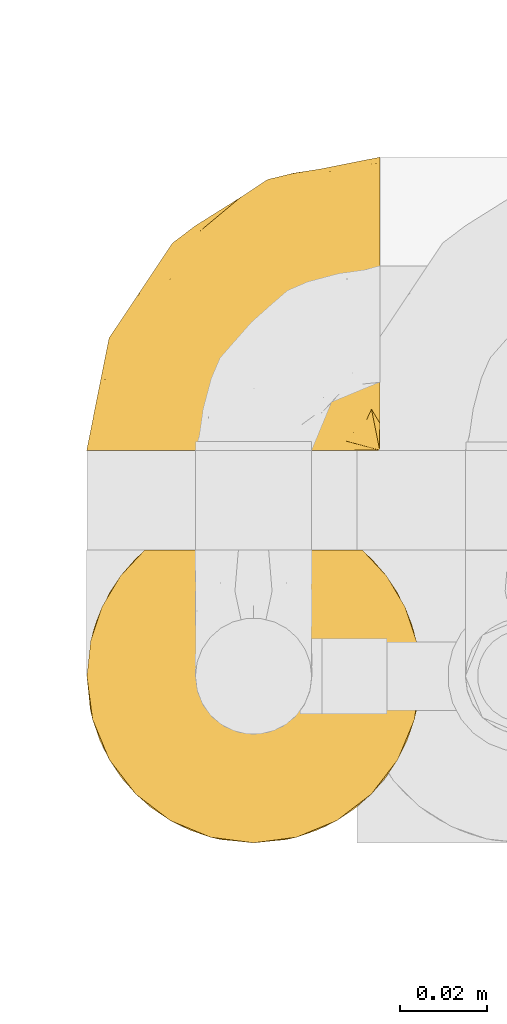
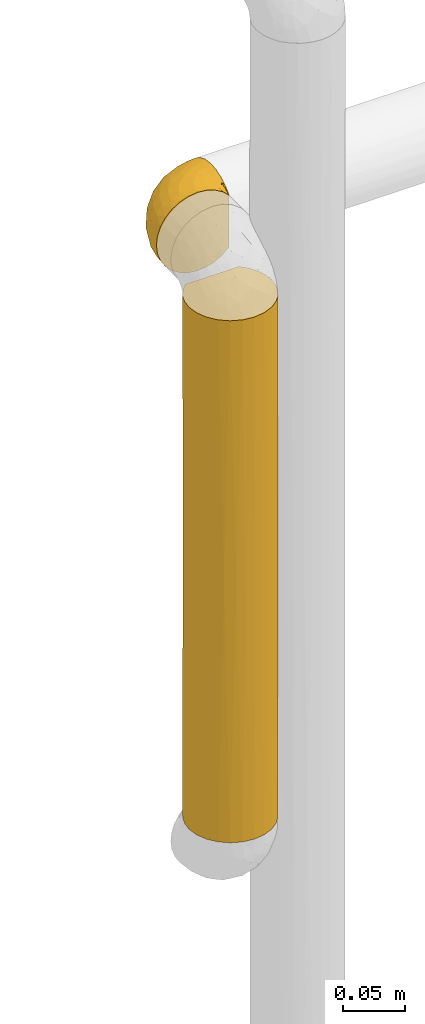
# One storey, part 333 of 827: 2 coverings.
"""IFC2X3 building model written with IfcOpenShell, lengths in millimetres."""

from ifc_helpers import new_model, entity, si_unit, converted_unit, derived_unit, direction, frame, origin, place, context, subcontext, project, spatial, faceted_brep, element, save


model = new_model("IFC2X3")

# Units and contexts
model_context = context("Model", 3, precision=0.01, world=origin(), true_north=direction((6.12303176911189e-17, 1.0)))
body_context = subcontext(model_context, "Body", "Model", "MODEL_VIEW")
ifc_project = project(units=[si_unit("LENGTHUNIT", "METRE", prefix="MILLI"), si_unit("AREAUNIT", "SQUARE_METRE"), si_unit("VOLUMEUNIT", "CUBIC_METRE"), converted_unit("PLANEANGLEUNIT", "DEGREE", entity("IfcRatioMeasure", 0.0174532925199433), si_unit("PLANEANGLEUNIT", "RADIAN"), dimensions=[0, 0, 0, 0, 0, 0, 0]), si_unit("MASSUNIT", "GRAM", prefix="KILO"), derived_unit("MASSDENSITYUNIT", [(si_unit("MASSUNIT", "GRAM", prefix="KILO"), 1), (si_unit("LENGTHUNIT", "METRE"), -3)]), derived_unit("MOMENTOFINERTIAUNIT", [(si_unit("LENGTHUNIT", "METRE"), 4)]), si_unit("TIMEUNIT", "SECOND"), si_unit("FREQUENCYUNIT", "HERTZ"), si_unit("THERMODYNAMICTEMPERATUREUNIT", "DEGREE_CELSIUS"), derived_unit("THERMALTRANSMITTANCEUNIT", [(si_unit("MASSUNIT", "GRAM", prefix="KILO"), 1), (si_unit("THERMODYNAMICTEMPERATUREUNIT", "KELVIN"), -1), (si_unit("TIMEUNIT", "SECOND"), -3)]), derived_unit("VOLUMETRICFLOWRATEUNIT", [(si_unit("LENGTHUNIT", "METRE"), 3), (si_unit("TIMEUNIT", "SECOND"), -1)]), derived_unit("MASSFLOWRATEUNIT", [(si_unit("MASSUNIT", "GRAM", prefix="KILO"), 1), (si_unit("TIMEUNIT", "SECOND"), -1)]), derived_unit("ROTATIONALFREQUENCYUNIT", [(si_unit("TIMEUNIT", "SECOND"), -1)]), si_unit("ELECTRICCURRENTUNIT", "AMPERE"), si_unit("ELECTRICVOLTAGEUNIT", "VOLT"), si_unit("POWERUNIT", "WATT"), si_unit("FORCEUNIT", "NEWTON", prefix="KILO"), si_unit("ILLUMINANCEUNIT", "LUX"), si_unit("LUMINOUSFLUXUNIT", "LUMEN"), si_unit("LUMINOUSINTENSITYUNIT", "CANDELA"), derived_unit("USERDEFINED", [(si_unit("MASSUNIT", "GRAM", prefix="KILO"), -1), (si_unit("LENGTHUNIT", "METRE"), -2), (si_unit("TIMEUNIT", "SECOND"), 3), (si_unit("LUMINOUSFLUXUNIT", "LUMEN"), 1)]), derived_unit("LINEARVELOCITYUNIT", [(si_unit("LENGTHUNIT", "METRE"), 1), (si_unit("TIMEUNIT", "SECOND"), -1)]), si_unit("PRESSUREUNIT", "PASCAL"), derived_unit("USERDEFINED", [(si_unit("LENGTHUNIT", "METRE"), -2), (si_unit("MASSUNIT", "GRAM", prefix="KILO"), 1), (si_unit("TIMEUNIT", "SECOND"), -2)]), derived_unit("LINEARFORCEUNIT", [(si_unit("MASSUNIT", "GRAM", prefix="KILO"), 1), (si_unit("LENGTHUNIT", "METRE"), 1), (si_unit("TIMEUNIT", "SECOND"), -2), (si_unit("LENGTHUNIT", "METRE"), -1)]), derived_unit("PLANARFORCEUNIT", [(si_unit("MASSUNIT", "GRAM", prefix="KILO"), 1), (si_unit("LENGTHUNIT", "METRE"), 1), (si_unit("TIMEUNIT", "SECOND"), -2), (si_unit("LENGTHUNIT", "METRE"), -2)])], contexts=[model_context])

# Site, building, storey
site_placement = place(None, origin())
site = spatial("IfcSite", under=ifc_project, at=site_placement, CompositionType="ELEMENT")
building_placement = place(site_placement, origin())
building = spatial("IfcBuilding", under=site, at=building_placement, CompositionType="ELEMENT")
storey_placement = place(building_placement, frame((0.0, 0.0, 28200.0)))
storey = spatial("IfcBuildingStorey", under=building, at=storey_placement, Name="08", CompositionType="ELEMENT", Elevation=28200.0)

# Coverings
covering_1_placement = place(storey_placement, frame((34953.73, 19463.91, 1659.95)))
element("IfcCovering", 1, at=covering_1_placement, inside=storey, Name=":ADSK_", ObjectType=":ADSK_", PredefinedType="INSULATION", context=body_context, shape_type="Brep", body=[
    faceted_brep([(23.36, 1.6, 74.68), (16.07, 1.6, 70.1), (9.98, 1.6, 64.01), (5.4, 1.6, 56.72), (2.56, 1.6, 48.6), (1.6, 1.6, 40.05), (2.56, 1.6, 31.49), (5.41, 1.6, 23.36), (9.99, 1.6, 16.07), (16.08, 1.6, 9.98), (23.37, 1.6, 5.4), (31.49, 1.6, 2.56), (40.05, 1.6, 1.6), (48.15, 1.6, 2.46), (55.88, 1.6, 5.01), (62.9, 1.6, 9.13), (68.89, 1.6, 14.62), (68.89, 1.6, 16.82), (68.89, 1.6, 18.56), (68.89, 1.6, 20.52), (68.89, 1.6, 22.49), (68.89, 1.6, 24.46), (68.89, 1.6, 26.42), (68.89, 1.6, 28.39), (68.89, 1.6, 30.36), (68.89, 1.6, 32.55), (68.89, 1.6, 34.75), (68.89, 1.6, 36.94), (68.89, 1.6, 39.13), (68.89, 1.6, 41.33), (68.89, 1.6, 43.52), (68.89, 1.6, 45.72), (68.89, 1.6, 47.91), (68.89, 1.6, 50.11), (68.89, 1.6, 52.3), (68.89, 1.6, 54.49), (68.89, 1.6, 56.69), (68.89, 1.6, 58.88), (68.89, 1.6, 61.08), (68.89, 1.6, 63.27), (68.89, 1.6, 65.47), (62.89, 1.6, 70.97), (55.86, 1.6, 75.09), (48.13, 1.6, 77.64), (40.05, 1.6, 78.5), (31.49, 1.6, 77.53), (69.15, 1.85, 14.62), (69.15, 7.85, 9.12), (69.15, 14.87, 5.0), (69.15, 22.6, 2.46), (69.15, 30.7, 1.6), (69.15, 40.65, 2.91), (69.15, 49.92, 6.75), (69.15, 57.88, 12.86), (69.15, 63.99, 20.82), (69.15, 67.84, 30.09), (69.15, 69.15, 40.05), (69.15, 67.84, 50.0), (69.15, 63.99, 59.27), (69.15, 57.88, 67.23), (69.15, 49.92, 73.34), (69.15, 40.65, 77.19), (69.15, 30.7, 78.5), (69.15, 22.6, 77.63), (69.15, 14.87, 75.09), (69.15, 7.85, 70.97), (69.15, 1.85, 65.47), (69.15, 1.85, 63.27), (69.15, 1.85, 62.29), (69.15, 1.85, 60.7), (69.15, 1.85, 59.11), (69.15, 1.85, 57.52), (69.15, 1.85, 55.93), (69.15, 1.85, 54.34), (69.15, 1.85, 52.76), (69.15, 1.85, 51.17), (69.15, 1.85, 49.58), (69.15, 1.85, 47.99), (69.15, 1.85, 46.4), (69.15, 1.85, 44.81), (69.15, 1.85, 43.22), (69.15, 1.85, 41.63), (69.15, 1.85, 40.05), (69.15, 1.85, 38.46), (69.15, 1.85, 36.87), (69.15, 1.85, 35.28), (69.15, 1.85, 33.69), (69.15, 1.85, 32.1), (69.15, 1.85, 30.51), (69.15, 1.85, 28.92), (69.15, 1.85, 27.33), (69.15, 1.85, 25.37), (69.15, 1.85, 23.4), (69.15, 1.85, 21.21), (69.15, 1.85, 19.01), (69.15, 1.85, 16.82), (68.96, 1.77, 42.32), (68.97, 1.78, 44.02), (68.97, 1.77, 47.13), (68.97, 1.77, 48.74), (68.95, 1.76, 23.57), (68.96, 1.77, 25.13), (68.98, 1.79, 61.34), (68.97, 1.78, 22.02), (68.97, 1.78, 29.72), (68.98, 1.78, 56.73), (68.97, 1.78, 55.14), (68.97, 1.78, 37.66), (68.94, 1.74, 64.12), (68.98, 1.78, 28.13), (68.98, 1.78, 26.62), (68.96, 1.77, 31.46), (68.97, 1.78, 16.16), (68.98, 1.78, 39.16), (68.98, 1.78, 50.37), (68.97, 1.77, 17.69), (68.96, 1.77, 19.17), (68.97, 1.77, 62.78), (68.97, 1.78, 58.35), (68.98, 1.78, 45.53), (68.96, 1.77, 59.91), (68.97, 1.77, 65.47), (68.94, 1.72, 65.47), (68.92, 1.66, 65.47), (68.97, 1.77, 14.62), (69.02, 1.8, 14.62), (69.08, 1.82, 14.62), (68.98, 1.79, 20.59), (68.97, 1.78, 32.99), (68.98, 1.79, 34.48), (68.97, 1.78, 51.91), (69.08, 1.82, 65.47), (69.02, 1.8, 65.47), (68.96, 1.76, 53.48), (68.92, 1.66, 14.62), (68.94, 1.72, 14.62), (68.97, 1.78, 40.77), (68.96, 1.77, 35.97), (67.02, 9.41, 7.84), (63.33, 17.65, 3.53), (64.61, 7.41, 8.32), (49.27, 21.47, 1.6), (51.4, 15.21, 2.19), (43.94, 16.15, 1.6), (61.87, 28.75, 1.6), (61.54, 13.67, 4.57), (57.95, 12.79, 3.96), (56.12, 19.18, 2.28), (63.4, 29.16, 1.6), (65.41, 9.04, 7.69), (53.1, 7.41, 3.53), (63.04, 5.74, 8.32), (61.33, 3.72, 7.84), (41.99, 8.87, 1.6), (54.6, 26.8, 1.6), (56.6, 9.53, 4.34), (41.58, 7.34, 1.6), (13.72, 37.63, 29.63), (5.82, 17.92, 27.34), (6.74, 27.45, 40.05), (58.82, 37.01, 2.39), (51.58, 34.22, 2.43), (42.09, 45.87, 9.07), (46.12, 56.57, 16.64), (55.56, 52.31, 9.54), (52.38, 42.07, 4.52), (61.54, 44.74, 4.52), (23.76, 21.49, 7.49), (20.5, 11.02, 7.49), (14.64, 15.64, 12.85), (41.77, 26.02, 2.35), (16.28, 36.59, 22.66), (49.4, 65.49, 32.9), (52.34, 63.99, 25.33), (4.3, 15.2, 40.05), (58.67, 60.27, 16.64), (25.26, 45.25, 19.99), (20.17, 35.21, 16.37), (34.7, 22.52, 3.26), (28.67, 12.03, 3.75), (8.62, 13.32, 19.58), (33.37, 35.9, 7.5), (41.35, 33.87, 4.04), (17.15, 25.73, 13.94), (12.68, 26.34, 19.58), (21.47, 46.78, 28.21), (41.11, 59.54, 24.75), (37.53, 60.18, 31.42), (30.64, 53.93, 26.2), (26.66, 53.36, 33.36), (21.38, 49.36, 40.05), (14.06, 38.4, 40.05), (55.54, 66.44, 40.05), (35.17, 50.09, 16.14), (29.04, 41.08, 12.85), (24.34, 31.14, 10.47), (29.33, 28.19, 6.49), (43.3, 64.0, 40.05), (32.34, 56.68, 40.05), (57.75, 43.9, 75.57), (49.41, 65.46, 47.37), (27.85, 52.22, 52.91), (13.7, 37.61, 50.46), (14.63, 15.64, 67.23), (8.61, 13.31, 60.5), (48.85, 50.02, 70.55), (54.13, 59.28, 63.45), (37.84, 53.05, 62.61), (23.75, 21.48, 72.6), (20.49, 11.01, 72.6), (28.66, 12.03, 76.34), (20.83, 41.02, 59.34), (55.15, 35.39, 77.76), (54.6, 26.8, 78.5), (61.87, 28.75, 78.5), (41.58, 7.34, 78.5), (57.58, 65.81, 53.16), (59.91, 53.28, 70.55), (36.94, 59.8, 48.88), (45.72, 61.82, 54.76), (5.82, 17.91, 52.74), (37.91, 41.4, 71.93), (50.18, 40.48, 75.79), (12.67, 26.34, 60.5), (49.29, 31.68, 77.86), (42.64, 27.68, 77.64), (43.94, 16.15, 78.5), (49.27, 21.47, 78.5), (19.45, 28.05, 67.23), (34.7, 22.54, 76.82), (41.99, 8.87, 78.5), (62.29, 37.3, 77.8), (29.01, 41.07, 67.23), (31.47, 32.24, 73.2), (37.18, 47.4, 67.66), (43.45, 35.77, 75.99), (63.33, 17.65, 76.57), (67.23, 11.06, 73.21), (66.07, 8.55, 71.93), (65.22, 6.63, 71.07), (61.99, 12.77, 75.09), (57.95, 12.79, 76.13), (53.09, 7.41, 76.57), (56.84, 18.97, 77.69), (61.33, 3.72, 72.26), (63.06, 5.76, 71.77), (51.41, 15.21, 77.9), (56.61, 9.52, 75.75)], [[[0, 1, 2, 3, 4, 5, 6, 7, 8, 9, 10, 11, 12, 13, 14, 15, 16, 17, 18, 19, 20, 21, 22, 23, 24, 25, 26, 27, 28, 29, 30, 31, 32, 33, 34, 35, 36, 37, 38, 39, 40, 41, 42, 43, 44, 45]], [[46, 47, 48, 49, 50, 51, 52, 53, 54, 55, 56, 57, 58, 59, 60, 61, 62, 63, 64, 65, 66, 67, 68, 69, 70, 71, 72, 73, 74, 75, 76, 77, 78, 79, 80, 81, 82, 83, 84, 85, 86, 87, 88, 89, 90, 91, 92, 93, 94, 95]], [[96, 97, 30]], [[98, 77, 99]], [[100, 101, 21]], [[69, 68, 102]], [[20, 19, 103]], [[24, 23, 104]], [[20, 103, 100]], [[72, 105, 106]], [[84, 83, 107]], [[89, 88, 104]], [[108, 67, 66]], [[109, 110, 90]], [[111, 25, 24]], [[112, 17, 16]], [[82, 113, 83]], [[109, 23, 22]], [[114, 76, 75]], [[105, 36, 106]], [[104, 111, 24]], [[18, 115, 116]], [[97, 96, 80]], [[67, 108, 117]], [[105, 71, 118]], [[31, 97, 119]], [[102, 120, 69]], [[108, 121, 122, 123, 40]], [[112, 95, 115]], [[17, 115, 18]], [[94, 116, 115]], [[117, 68, 67]], [[38, 117, 39]], [[112, 124, 125, 126, 46]], [[17, 112, 115]], [[70, 120, 118]], [[39, 117, 108]], [[120, 38, 37]], [[120, 37, 118]], [[120, 70, 69]], [[116, 94, 127]], [[128, 86, 129]], [[117, 38, 102]], [[74, 130, 75]], [[99, 33, 32]], [[115, 95, 94]], [[39, 108, 40]], [[108, 66, 131, 132, 121]], [[105, 72, 71]], [[118, 37, 36]], [[71, 70, 118]], [[35, 106, 36]], [[36, 105, 118]], [[35, 133, 106]], [[74, 73, 133]], [[106, 133, 73]], [[99, 114, 33]], [[133, 35, 34]], [[73, 72, 106]], [[95, 112, 46]], [[112, 16, 134, 135, 124]], [[130, 114, 75]], [[99, 76, 114]], [[114, 130, 33]], [[34, 33, 130]], [[78, 77, 98]], [[98, 119, 78]], [[130, 133, 34]], [[133, 130, 74]], [[79, 97, 80]], [[98, 99, 32]], [[98, 32, 31]], [[77, 76, 99]], [[97, 79, 119]], [[136, 96, 29]], [[30, 97, 31]], [[136, 29, 28]], [[81, 80, 96]], [[29, 96, 30]], [[31, 119, 98]], [[119, 79, 78]], [[96, 136, 81]], [[82, 81, 136]], [[113, 107, 83]], [[84, 107, 137]], [[107, 27, 137]], [[113, 28, 107]], [[27, 107, 28]], [[85, 84, 137]], [[137, 27, 26]], [[113, 136, 28]], [[136, 113, 82]], [[109, 89, 104]], [[86, 85, 129]], [[89, 109, 90]], [[111, 87, 128]], [[26, 129, 137]], [[88, 111, 104]], [[25, 111, 128]], [[22, 110, 109]], [[23, 109, 104]], [[110, 91, 90]], [[100, 92, 101]], [[110, 22, 101]], [[91, 110, 101]], [[116, 19, 18]], [[111, 88, 87]], [[127, 103, 19]], [[25, 128, 26]], [[86, 128, 87]], [[128, 129, 26]], [[137, 129, 85]], [[120, 102, 38]], [[117, 102, 68]], [[91, 101, 92]], [[21, 101, 22]], [[93, 92, 103]], [[100, 21, 20]], [[100, 103, 92]], [[127, 93, 103]], [[93, 127, 94]], [[116, 127, 19]], [[126, 138, 47]], [[48, 138, 139]], [[140, 125, 124]], [[141, 142, 143]], [[144, 49, 139]], [[145, 140, 146]], [[48, 139, 49]], [[139, 145, 147]], [[49, 144, 148, 50]], [[126, 125, 149]], [[14, 13, 150]], [[151, 146, 140]], [[149, 140, 145]], [[152, 151, 135]], [[152, 14, 150]], [[16, 15, 134]], [[13, 153, 150]], [[124, 151, 140]], [[141, 147, 142]], [[14, 152, 15]], [[15, 152, 134]], [[47, 46, 126]], [[139, 154, 144]], [[138, 48, 47]], [[125, 140, 149]], [[135, 134, 152]], [[146, 155, 142]], [[145, 146, 147]], [[149, 139, 138]], [[147, 141, 154]], [[147, 146, 142]], [[139, 147, 154]], [[139, 149, 145]], [[149, 138, 126]], [[155, 146, 151]], [[150, 143, 142]], [[152, 155, 151]], [[150, 142, 155]], [[13, 12, 156, 153]], [[153, 143, 150]], [[152, 150, 155]], [[151, 124, 135]], [[157, 158, 159]], [[160, 154, 161]], [[162, 163, 164]], [[165, 166, 160]], [[167, 168, 169]], [[141, 170, 161]], [[156, 12, 11]], [[158, 157, 171]], [[172, 55, 173]], [[158, 6, 174]], [[175, 54, 53]], [[52, 166, 164]], [[52, 164, 53]], [[54, 175, 173]], [[166, 52, 51]], [[176, 177, 171]], [[178, 143, 179]], [[156, 11, 179]], [[8, 7, 180]], [[169, 9, 8]], [[179, 143, 153, 156]], [[179, 11, 10]], [[168, 179, 10]], [[181, 162, 182]], [[179, 167, 178]], [[183, 184, 177]], [[183, 169, 184]], [[176, 171, 185]], [[172, 186, 187]], [[158, 7, 6]], [[159, 158, 174]], [[184, 180, 158]], [[54, 173, 55]], [[180, 169, 8]], [[188, 189, 187]], [[9, 168, 10]], [[186, 188, 187]], [[190, 157, 159, 191]], [[55, 172, 192]], [[176, 193, 194]], [[161, 170, 182]], [[162, 164, 165]], [[175, 164, 163]], [[51, 50, 148]], [[167, 195, 196]], [[178, 182, 170]], [[6, 5, 174]], [[158, 180, 7]], [[169, 180, 184]], [[169, 168, 9]], [[179, 168, 167]], [[182, 162, 165]], [[162, 194, 193]], [[161, 165, 160]], [[195, 181, 196]], [[192, 172, 197]], [[192, 56, 55]], [[189, 190, 198]], [[198, 197, 187]], [[172, 187, 197]], [[185, 189, 188]], [[198, 187, 189]], [[186, 172, 173]], [[173, 163, 186]], [[193, 186, 163]], [[176, 185, 188]], [[185, 157, 190]], [[188, 186, 193]], [[177, 176, 194]], [[188, 193, 176]], [[162, 193, 163]], [[195, 177, 194]], [[171, 177, 184]], [[181, 195, 194]], [[183, 167, 169]], [[162, 181, 194]], [[196, 182, 178]], [[158, 171, 184]], [[171, 157, 185]], [[177, 195, 183]], [[167, 183, 195]], [[182, 196, 181]], [[178, 170, 143]], [[178, 167, 196]], [[164, 175, 53]], [[173, 175, 163]], [[160, 51, 148]], [[164, 166, 165]], [[51, 160, 166]], [[160, 148, 144, 154]], [[141, 161, 154]], [[182, 165, 161]], [[190, 189, 185]], [[143, 170, 141]], [[60, 199, 61]], [[197, 200, 192]], [[201, 190, 202]], [[200, 57, 192]], [[203, 204, 2]], [[205, 206, 207]], [[208, 209, 210]], [[211, 207, 201]], [[212, 213, 214]], [[45, 215, 210]], [[216, 206, 58]], [[45, 44, 215]], [[59, 217, 60]], [[60, 217, 199]], [[0, 45, 210]], [[218, 201, 219]], [[202, 159, 220]], [[205, 221, 222]], [[223, 204, 203]], [[1, 203, 2]], [[57, 200, 216]], [[220, 3, 204]], [[220, 174, 4]], [[1, 0, 209]], [[212, 224, 213]], [[225, 226, 227]], [[228, 223, 203]], [[208, 210, 229]], [[210, 226, 229]], [[3, 220, 4]], [[58, 206, 59]], [[209, 203, 1]], [[202, 220, 223]], [[228, 203, 208]], [[202, 211, 201]], [[3, 2, 204]], [[202, 190, 191, 159]], [[210, 215, 230, 226]], [[199, 212, 231]], [[232, 233, 221]], [[233, 208, 229]], [[207, 206, 219]], [[217, 206, 205]], [[227, 224, 225]], [[233, 232, 228]], [[201, 207, 219]], [[234, 232, 221]], [[218, 219, 200]], [[202, 223, 211]], [[174, 220, 159]], [[174, 5, 4]], [[61, 231, 62]], [[220, 204, 223]], [[210, 209, 0]], [[203, 209, 208]], [[225, 233, 229]], [[224, 227, 213]], [[221, 233, 235]], [[57, 56, 192]], [[198, 218, 197]], [[200, 219, 216]], [[201, 198, 190]], [[197, 218, 200]], [[198, 201, 218]], [[206, 216, 219]], [[58, 57, 216]], [[231, 212, 214]], [[222, 212, 199]], [[228, 211, 223]], [[207, 211, 232]], [[62, 231, 214]], [[199, 231, 61]], [[233, 228, 208]], [[211, 228, 232]], [[222, 221, 235]], [[234, 205, 207]], [[206, 217, 59]], [[199, 217, 205]], [[205, 222, 199]], [[224, 222, 235]], [[222, 224, 212]], [[224, 235, 225]], [[233, 225, 235]], [[226, 225, 229]], [[205, 234, 221]], [[207, 232, 234]], [[63, 214, 236]], [[214, 213, 236]], [[214, 63, 62]], [[237, 236, 238]], [[238, 132, 131]], [[236, 237, 64]], [[239, 240, 241]], [[63, 236, 64]], [[131, 66, 65]], [[237, 131, 65]], [[242, 230, 43]], [[237, 65, 64]], [[239, 121, 132]], [[42, 242, 43]], [[241, 240, 243]], [[41, 123, 244]], [[43, 230, 215, 44]], [[244, 122, 245]], [[227, 246, 243]], [[241, 247, 245]], [[121, 239, 245]], [[41, 40, 123]], [[132, 238, 239]], [[244, 42, 41]], [[131, 237, 238]], [[240, 239, 238]], [[245, 239, 241]], [[247, 241, 246]], [[247, 244, 245]], [[238, 236, 240]], [[243, 236, 213]], [[236, 243, 240]], [[227, 226, 246]], [[243, 213, 227]], [[242, 246, 226]], [[243, 246, 241]], [[246, 242, 247]], [[244, 247, 242]], [[242, 226, 230]], [[42, 244, 242]], [[122, 244, 123]], [[122, 121, 245]]]),
])
covering_2_placement = place(storey_placement, frame((34953.78, 19373.44, 1159.55)))
element("IfcCovering", 2, at=covering_2_placement, inside=storey, Name=":ADSK_", ObjectType=":ADSK_", PredefinedType="INSULATION", context=body_context, shape_type="Brep", body=[
    faceted_brep([(2.9, 30.06, 0.0), (1.6, 40.0, 0.0), (2.9, 49.93, 0.0), (6.74, 59.2, 0.0), (12.84, 67.15, 0.0), (20.8, 73.25, 0.0), (30.06, 77.09, 0.0), (40.0, 78.4, 0.0), (49.93, 77.09, 0.0), (59.2, 73.25, 0.0), (67.15, 67.15, 0.0), (73.25, 59.2, 0.0), (77.09, 49.93, 0.0), (78.4, 40.0, 0.0), (77.09, 30.06, 0.0), (73.25, 20.8, 0.0), (67.15, 12.84, 0.0), (59.2, 6.74, 0.0), (49.93, 2.9, 0.0), (40.0, 1.6, 0.0), (30.06, 2.9, 0.0), (20.8, 6.74, 0.0), (12.84, 12.84, 0.0), (6.74, 20.8, 0.0), (1.6, 40.0, 511.35), (2.9, 30.06, 511.35), (6.74, 20.8, 511.35), (12.84, 12.84, 511.35), (20.8, 6.74, 511.35), (30.06, 2.9, 511.35), (40.0, 1.6, 511.35), (49.93, 2.9, 511.35), (59.2, 6.74, 511.35), (67.15, 12.84, 511.35), (73.25, 20.8, 511.35), (77.09, 30.06, 511.35), (78.4, 40.0, 511.35), (77.51, 48.2, 511.35), (74.9, 56.01, 511.35), (70.68, 63.08, 511.35), (65.05, 69.1, 511.35), (14.94, 69.1, 511.35), (9.31, 63.08, 511.35), (5.09, 56.01, 511.35), (2.48, 48.2, 511.35), (1.6, 40.0, 294.98), (3.58, 52.17, 265.05), (33.21, 77.79, 502.66), (40.0, 78.4, 502.05), (40.0, 78.4, 285.68), (1.6, 40.0, 255.68), (23.43, 74.64, 190.49), (9.53, 63.37, 235.27), (17.47, 71.1, 251.43), (26.63, 76.0, 504.45), (29.81, 77.02, 261.33), (20.48, 73.07, 507.38), (53.36, 76.0, 504.45), (59.51, 73.07, 507.38), (56.67, 74.59, 320.84), (62.52, 71.1, 251.43), (50.18, 77.02, 261.33), (46.78, 77.79, 502.66), (70.46, 63.37, 235.27), (76.41, 52.17, 265.05), (78.4, 40.0, 294.98), (78.4, 40.0, 216.37), (77.64, 32.43, 207.9), (75.47, 25.3, 250.93), (47.49, 2.33, 209.9), (54.69, 4.52, 255.68), (70.46, 16.62, 255.68), (63.37, 9.53, 250.93), (40.0, 1.6, 255.68), (40.0, 1.6, 216.37), (32.43, 2.35, 207.9), (25.3, 4.52, 250.93), (2.33, 32.5, 209.9), (4.52, 25.3, 255.68), (16.62, 9.53, 255.68), (9.53, 16.62, 250.93)], [[[0, 1, 2, 3, 4, 5, 6, 7, 8, 9, 10, 11, 12, 13, 14, 15, 16, 17, 18, 19, 20, 21, 22, 23]], [[24, 25, 26, 27, 28, 29, 30, 31, 32, 33, 34, 35, 36, 37, 38, 39, 40, 41, 42, 43, 44]], [[45, 44, 46]], [[47, 48, 49]], [[2, 1, 50, 45]], [[6, 5, 51]], [[52, 46, 43]], [[45, 24, 44]], [[43, 42, 52]], [[46, 52, 3]], [[2, 46, 3]], [[4, 3, 52]], [[45, 46, 2]], [[53, 52, 41]], [[44, 43, 46]], [[51, 54, 55]], [[53, 4, 52]], [[47, 55, 54]], [[5, 4, 53]], [[49, 55, 47]], [[51, 56, 54]], [[56, 51, 53]], [[51, 5, 53]], [[7, 6, 55]], [[55, 49, 7]], [[6, 51, 55]], [[56, 53, 41]], [[52, 42, 41]], [[57, 58, 59]], [[10, 9, 60]], [[40, 60, 58]], [[61, 62, 57]], [[63, 40, 39]], [[60, 59, 58]], [[49, 62, 61]], [[61, 8, 7]], [[62, 49, 48]], [[59, 9, 61]], [[49, 61, 7]], [[61, 9, 8]], [[38, 64, 63]], [[38, 37, 64]], [[9, 59, 60]], [[57, 59, 61]], [[12, 65, 66, 13]], [[37, 36, 65]], [[10, 63, 11]], [[60, 63, 10]], [[11, 63, 64]], [[65, 64, 37]], [[11, 64, 12]], [[63, 39, 38]], [[40, 63, 60]], [[65, 12, 64]], [[67, 35, 68]], [[31, 69, 70]], [[67, 13, 66, 65, 36]], [[68, 71, 15]], [[71, 68, 34]], [[67, 36, 35]], [[33, 71, 34]], [[71, 16, 15]], [[15, 14, 68]], [[32, 70, 72]], [[69, 30, 73, 74, 19]], [[70, 32, 31]], [[70, 17, 72]], [[33, 72, 71]], [[16, 71, 72]], [[32, 72, 33]], [[67, 68, 14]], [[17, 16, 72]], [[70, 69, 18]], [[17, 70, 18]], [[34, 68, 35]], [[69, 31, 30]], [[13, 67, 14]], [[69, 19, 18]], [[75, 29, 76]], [[25, 77, 78]], [[75, 19, 74, 73, 30]], [[76, 79, 21]], [[79, 76, 28]], [[75, 30, 29]], [[27, 79, 28]], [[79, 22, 21]], [[21, 20, 76]], [[26, 78, 80]], [[1, 77, 24, 45, 50]], [[78, 26, 25]], [[78, 23, 80]], [[27, 80, 79]], [[22, 79, 80]], [[26, 80, 27]], [[75, 76, 20]], [[23, 22, 80]], [[78, 77, 0]], [[23, 78, 0]], [[28, 76, 29]], [[77, 25, 24]], [[19, 75, 20]], [[77, 1, 0]], [[58, 57, 62, 48, 47, 54, 56, 41, 40]]]),
])

save(model, "model.ifc")
